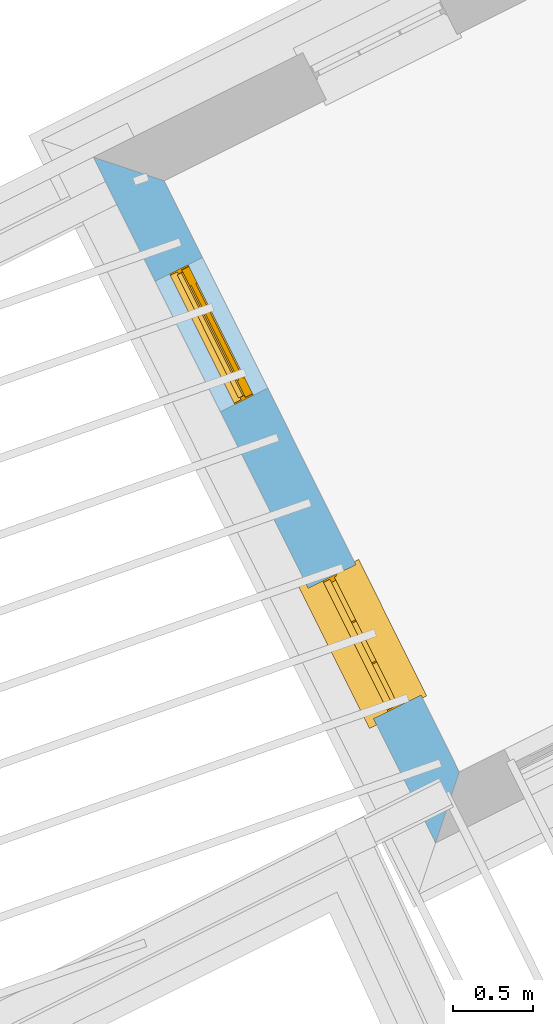
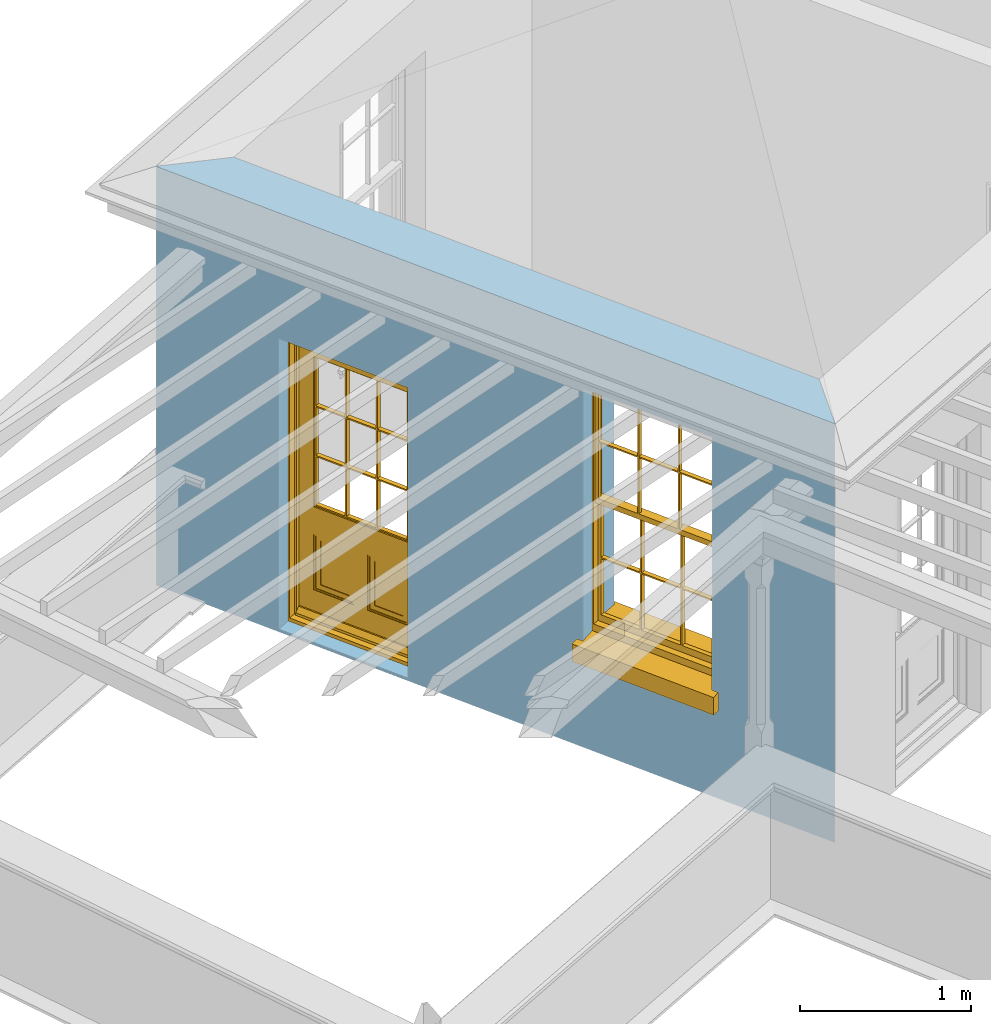
# One storey, part 3 of 7: 1 door, 1 window, 2 openings, plus 1 element that does not belong to this part.
"""IFC2X3 building model written with IfcOpenShell, lengths in metres."""

from ifc_helpers import new_model, si_unit, frame, origin, place, context, subcontext, project, spatial, polyline, outline, extrude, faceted_brep, material, layer, layer_set, layer_usage, element, fill, save


model = new_model("IFC2X3")

# Units and contexts
model_context = context("Model", 3, world=origin())
body_context = subcontext(model_context, "Body", "Model", "MODEL_VIEW")
ifc_project = project(units=[si_unit("PLANEANGLEUNIT", "RADIAN"), si_unit("MASSUNIT", "GRAM", prefix="KILO"), si_unit("FORCEUNIT", "NEWTON", prefix="KILO"), si_unit("LENGTHUNIT", "METRE")], contexts=[model_context])

# Site, building, storey
site_placement = place(None, origin())
site = spatial("IfcSite", under=ifc_project, at=site_placement, CompositionType="ELEMENT")
building_placement = place(None, origin())
building = spatial("IfcBuilding", under=site, at=building_placement, Name="Building plot-8", CompositionType="ELEMENT")
storey_placement = place(None, frame((0.0, 0.0, 6.3)))
storey = spatial("IfcBuildingStorey", under=building, at=storey_placement, Name="Floor 2", CompositionType="ELEMENT", Elevation=6.3)

# Wall, openings, door, window
ifc_material = material(Name="Masonry")
ifc_layer = layer(ifc_material, 0.33, ventilated=False)
ifc_layer_set = layer_set([ifc_layer], Name="My Wall")
ifc_layer_usage = layer_usage(ifc_layer_set, "AXIS2", "NEGATIVE", 0.08)
wall_placement = place(storey_placement, origin())
wall = element("IfcWallStandardCase", 1, at=wall_placement, inside=storey, material=ifc_layer_usage, Name="exterior", context=body_context, shape_type="SweptSolid", body=[
    extrude(outline(polyline([(22.6049906081901, 17.1432536383612), (22.162338538902, 17.2911020254168), (24.2955349008038, 13.0182468981183), (24.4433832878594, 13.4608989674064), (22.6049906081901, 17.1432536383612)])), origin(), (0.0, 0.0, 1.0), 3.0),
])
opening_1_placement = place(storey_placement, frame((0.0, 0.0, 0.0199999999999996)))
opening_1 = element("IfcOpeningElement", 2, at=opening_1_placement, cuts=wall, Name="Opening", ObjectType="Opening", context=body_context, shape_type="SweptSolid", body=[
    extrude(outline(polyline([(22.5482357882612, 16.518138471764), (22.9547075319454, 15.7039636001386), (23.2499577601173, 15.8513654412549), (22.843486016433, 16.6655403128803), (22.5482357882612, 16.518138471764)])), origin(), (0.0, 0.0, 1.0), 2.08),
])
opening_2_placement = place(storey_placement, frame((0.0, 0.0, 0.75)))
opening_2 = element("IfcOpeningElement", 3, at=opening_2_placement, cuts=wall, Name="Opening", ObjectType="Opening", context=body_context, shape_type="SweptSolid", body=[
    extrude(outline(polyline([(23.5031659077604, 14.6053853233965), (23.9096376514446, 13.791210451771), (24.2048878796165, 13.9386122928873), (23.7984161359322, 14.7527871645127), (23.5031659077604, 14.6053853233965)])), origin(), (0.0, 0.0, 1.0), 1.82),
])
door_placement = place(storey_placement, frame((22.7719102035429, 16.6298065332157, 0.0199999999999996), z_axis=(0.0, 0.0, 1.0), x_axis=(0.406471743684261, -0.814174871625426, 0.0)))
door = element("IfcDoor", 4, at=door_placement, inside=storey, Name="circulation outside door", OverallHeight=2.08, OverallWidth=0.91, context=body_context, shape_type="Brep", held_by="IfcProductRepresentation", body=[
    faceted_brep([(0.545, -0.055, 0.265), (0.745, -0.055, 0.265), (0.745, -0.05, 0.265), (0.545, -0.05, 0.265), (0.745, -0.05, 0.58), (0.545, -0.05, 0.58), (0.545, -0.055, 0.58), (0.515, -0.06, 0.235), (0.775, -0.06, 0.235), (0.745, -0.055, 0.58), (0.515, -0.06, 0.61), (0.515, -0.065, 0.235), (0.775, -0.065, 0.235), (0.775, -0.06, 0.61), (0.515, -0.065, 0.61), (0.785, -0.065, 0.225), (0.505, -0.065, 0.225), (0.775, -0.065, 0.61), (0.505, -0.065, 0.62), (0.785, -0.065, 0.62), (0.505, -0.07, 0.225), (0.785, -0.07, 0.225), (0.505, -0.07, 0.62), (0.785, -0.07, 0.62), (0.883, -0.07, 0.075), (0.898, -0.07, 0.075), (0.405, -0.07, 0.62), (0.405, -0.07, 0.225), (0.027, -0.07, 0.075), (0.785, -0.07, 0.82), (0.125, -0.07, 0.82), (0.405, -0.065, 0.62), (0.405, -0.065, 0.225), (0.898, -0.07, 2.068), (0.027, -0.08, 0.075), (0.883, -0.08, 0.075), (0.125, -0.07, 0.225), (0.012, -0.07, 0.075), (0.785, -0.06, 0.82), (0.125, -0.06, 0.82), (0.125, -0.07, 0.62), (0.125, -0.065, 0.62), (0.395, -0.065, 0.61), (0.395, -0.065, 0.235), (0.125, -0.065, 0.225), (0.785, -0.07, 1.895), (0.027, -0.11, 0.045), (0.883, -0.11, 0.045), (0.558333, -0.06, 0.83), (0.351667, -0.06, 0.83), (0.125, -0.07, 1.895), (0.125, -0.06, 1.895), (0.785, -0.06, 1.895), (0.012, -0.07, 2.068), (0.135, -0.065, 0.61), (0.395, -0.06, 0.61), (0.395, -0.06, 0.235), (0.135, -0.065, 0.235), (0.027, -0.11, 0.027), (0.883, -0.11, 0.027), (0.568333, -0.06, 0.83), (0.558333, -0.03, 0.83), (0.351667, -0.03, 0.83), (0.341667, -0.06, 0.83), (0.135, -0.06, 1.185), (0.135, -0.06, 1.53), (0.775, -0.06, 1.53), (0.775, -0.06, 1.185), (0.135, -0.06, 0.61), (0.365, -0.055, 0.58), (0.365, -0.055, 0.265), (0.135, -0.06, 0.235), (0.568333, -0.06, 1.175), (0.558333, -0.06, 1.175), (0.775, -0.06, 0.83), (0.558333, -0.03, 1.175), (0.785, -0.03, 0.82), (0.125, -0.03, 0.82), (0.351667, -0.03, 1.175), (0.351667, -0.06, 1.175), (0.341667, -0.06, 1.175), (0.135, -0.06, 0.83), (0.135, -0.06, 1.175), (0.135, -0.03, 1.185), (0.135, -0.03, 1.53), (0.135, -0.06, 1.54), (0.351667, -0.06, 1.885), (0.558333, -0.06, 1.885), (0.775, -0.03, 1.53), (0.775, -0.03, 1.185), (0.775, -0.06, 1.175), (0.775, -0.06, 1.54), (0.165, -0.055, 0.58), (0.365, -0.05, 0.58), (0.365, -0.05, 0.265), (0.165, -0.055, 0.265), (0.568333, -0.03, 0.83), (0.568333, -0.03, 1.175), (0.568333, -0.06, 1.185), (0.558333, -0.06, 1.185), (0.775, -0.03, 0.83), (0.785, -0.02, 0.82), (0.125, -0.02, 0.82), (0.341667, -0.03, 0.83), (0.341667, -0.03, 1.175), (0.351667, -0.06, 1.185), (0.341667, -0.06, 1.185), (0.135, -0.03, 0.83), (0.341667, -0.03, 1.185), (0.125, -0.03, 1.895), (0.341667, -0.03, 1.53), (0.341667, -0.06, 1.53), (0.135, -0.06, 1.885), (0.341667, -0.06, 1.54), (0.341667, -0.06, 1.885), (0.558333, -0.03, 1.885), (0.351667, -0.03, 1.885), (0.568333, -0.06, 1.885), (0.785, -0.03, 1.895), (0.568333, -0.03, 1.185), (0.568333, -0.06, 1.53), (0.568333, -0.03, 1.53), (0.568333, -0.06, 1.54), (0.775, -0.06, 1.885), (0.165, -0.05, 0.58), (0.165, -0.05, 0.265), (0.775, -0.03, 1.175), (0.558333, -0.06, 1.53), (0.351667, -0.03, 1.185), (0.558333, -0.03, 1.185), (0.505, -0.02, 0.62), (0.405, -0.02, 0.62), (0.125, -0.02, 1.895), (0.785, -0.02, 1.895), (0.351667, -0.06, 1.53), (0.135, -0.03, 1.175), (0.135, -0.03, 1.54), (0.341667, -0.03, 1.54), (0.135, -0.03, 1.885), (0.351667, -0.06, 1.54), (0.558333, -0.03, 1.54), (0.558333, -0.06, 1.54), (0.351667, -0.03, 1.54), (0.775, -0.03, 1.54), (0.568333, -0.03, 1.54), (0.775, -0.03, 1.885), (0.558333, -0.03, 1.53), (0.405, -0.02, 0.225), (0.505, -0.02, 0.225), (0.125, -0.02, 0.62), (0.785, -0.02, 0.62), (0.012, -0.02, 2.068), (0.898, -0.02, 2.068), (0.351667, -0.03, 1.53), (0.341667, -0.03, 1.885), (0.568333, -0.03, 1.885), (0.405, -0.025, 0.225), (0.405, -0.025, 0.62), (0.505, -0.025, 0.62), (0.505, -0.025, 0.225), (0.898, -0.02, 0.027), (0.012, -0.02, 0.027), (0.125, -0.025, 0.62), (0.785, -0.025, 0.62), (0.395, -0.025, 0.235), (0.395, -0.025, 0.61), (0.125, -0.02, 0.225), (0.125, -0.025, 0.225), (0.515, -0.025, 0.61), (0.515, -0.025, 0.235), (0.785, -0.02, 0.225), (0.785, -0.025, 0.225), (0.135, -0.025, 0.61), (0.775, -0.025, 0.61), (0.135, -0.025, 0.235), (0.395, -0.03, 0.235), (0.395, -0.03, 0.61), (0.515, -0.03, 0.61), (0.515, -0.03, 0.235), (0.775, -0.025, 0.235), (0.135, -0.03, 0.61), (0.775, -0.03, 0.61), (0.135, -0.03, 0.235), (0.365, -0.035, 0.265), (0.365, -0.035, 0.58), (0.545, -0.035, 0.58), (0.545, -0.035, 0.265), (0.775, -0.03, 0.235), (0.165, -0.035, 0.58), (0.745, -0.035, 0.58), (0.165, -0.035, 0.265), (0.365, -0.04, 0.58), (0.365, -0.04, 0.265), (0.545, -0.04, 0.58), (0.545, -0.04, 0.265), (0.745, -0.035, 0.265), (0.165, -0.04, 0.58), (0.745, -0.04, 0.58), (0.165, -0.04, 0.265), (0.745, -0.04, 0.265), (0.885, -0.072, 0.025), (0.025, -0.072, 0.025), (0.025, -0.1, 0.025), (0.885, -0.1, 0.025), (0.9, -0.02, 0.025), (0.01, -0.02, 0.025), (0.9, -0.072, 0.025), (0.91, -0.02, 0.0), (0.0, -0.02, 0.0), (0.01, -0.072, 0.025), (0.9, -0.072, 2.07), (0.9, -0.02, 2.07), (0.885, -0.072, 2.055), (0.91, -0.02, 2.08), (0.01, -0.02, 2.07), (0.0, -0.02, 2.08), (0.01, -0.072, 2.07), (0.025, -0.072, 2.055), (0.0, -0.15, 2.08), (0.91, -0.15, 2.08), (0.01, -0.15, 2.07), (0.9, -0.15, 2.07), (0.01, -0.1, 2.07), (0.9, -0.1, 2.07), (0.0, -0.15, 0.0), (0.91, -0.15, 0.0), (0.01, -0.15, 0.025), (0.9, -0.15, 0.025), (0.01, -0.1, 0.025), (0.025, -0.1, 2.055), (0.9, -0.1, 0.025), (0.885, -0.1, 2.055), (0.898, -0.07, 0.027), (0.012, -0.07, 0.027), (0.883, -0.07, 0.027), (0.027, -0.07, 0.027)], [[[0, 1, 2, 3]], [[2, 4, 5, 3]], [[0, 3, 5, 6]], [[1, 0, 7, 8]], [[9, 4, 2, 1]], [[9, 6, 5, 4]], [[0, 6, 10, 7]], [[8, 7, 11, 12]], [[8, 13, 9, 1]], [[13, 10, 6, 9]], [[7, 10, 14, 11]], [[15, 12, 11, 16]], [[12, 17, 13, 8]], [[17, 14, 10, 13]], [[18, 16, 11, 14]], [[15, 19, 17, 12]], [[15, 16, 20, 21]], [[14, 17, 19, 18]], [[16, 18, 22, 20]], [[21, 23, 19, 15]], [[24, 25, 21, 20]], [[23, 22, 18, 19]], [[20, 22, 26, 27]], [[23, 21, 25]], [[28, 24, 20, 27]], [[22, 23, 29]], [[29, 30, 26, 22]], [[27, 26, 31, 32]], [[23, 25, 33, 29]], [[34, 35, 24, 28]], [[28, 27, 36, 37]], [[38, 39, 30, 29]], [[26, 30, 40]], [[26, 40, 41, 31]], [[42, 43, 32, 31]], [[32, 44, 36, 27]], [[33, 45, 29]], [[46, 47, 35, 34]], [[36, 40, 37]], [[39, 38, 48, 49]], [[50, 30, 39, 51]], [[29, 45, 52, 38]], [[53, 37, 40, 30]], [[44, 41, 40, 36]], [[31, 41, 54, 42]], [[43, 42, 55, 56]], [[57, 44, 32, 43]], [[50, 45, 33, 53]], [[47, 46, 58, 59]], [[60, 48, 38]], [[49, 48, 61, 62]], [[49, 63, 39]], [[50, 53, 30]], [[51, 39, 64, 65]], [[45, 50, 51, 52]], [[66, 67, 38, 52]], [[57, 54, 41, 44]], [[42, 54, 68, 55]], [[56, 55, 69, 70]], [[56, 71, 57, 43]], [[60, 72, 73, 48]], [[60, 38, 74]], [[48, 73, 75, 61]], [[76, 77, 62, 61]], [[62, 78, 79, 49]], [[49, 79, 80, 63]], [[63, 81, 39]], [[82, 64, 39]], [[65, 64, 83, 84]], [[85, 51, 65]], [[52, 51, 86, 87]], [[88, 89, 67, 66]], [[90, 38, 67]], [[91, 66, 52]], [[71, 68, 54, 57]], [[55, 68, 92, 69]], [[69, 93, 94, 70]], [[70, 95, 71, 56]], [[96, 97, 72, 60]], [[73, 72, 98, 99]], [[74, 38, 90]], [[100, 96, 60, 74]], [[75, 73, 79, 78]], [[61, 75, 97, 96]], [[101, 102, 77, 76]], [[77, 103, 62]], [[96, 76, 61]], [[103, 104, 78, 62]], [[80, 79, 105, 106]], [[63, 80, 104, 103]], [[81, 63, 103, 107]], [[81, 82, 39]], [[106, 64, 82, 80]], [[106, 108, 83, 64]], [[84, 83, 77, 109]], [[110, 111, 65, 84]], [[112, 51, 85]], [[113, 85, 65, 111]], [[114, 86, 51]], [[115, 87, 86, 116]], [[117, 52, 87]], [[118, 76, 89, 88]], [[119, 98, 67, 89]], [[120, 121, 88, 66]], [[67, 98, 72, 90]], [[91, 122, 120, 66]], [[91, 52, 123]], [[95, 92, 68, 71]], [[69, 92, 124, 93]], [[94, 93, 124, 125]], [[94, 125, 95, 70]], [[72, 97, 126, 90]], [[127, 99, 98, 120]], [[99, 105, 79, 73]], [[74, 90, 126, 100]], [[96, 100, 76]], [[128, 129, 75, 78]], [[97, 75, 129, 119]], [[130, 131, 102, 101]], [[109, 77, 102, 132]], [[133, 101, 76, 118]], [[77, 107, 103]], [[78, 104, 108, 128]], [[111, 106, 105, 134]], [[104, 80, 82, 135]], [[107, 135, 82, 81]], [[110, 108, 106, 111]], [[104, 135, 83, 108]], [[83, 135, 77]], [[136, 84, 109]], [[110, 84, 136, 137]], [[114, 51, 112]], [[85, 136, 138, 112]], [[113, 137, 136, 85]], [[111, 134, 139, 113]], [[86, 114, 113, 139]], [[140, 141, 87, 115]], [[139, 142, 116, 86]], [[109, 118, 115, 116]], [[117, 123, 52]], [[117, 87, 141, 122]], [[126, 89, 76]], [[143, 118, 88]], [[120, 98, 119, 121]], [[119, 89, 126, 97]], [[144, 143, 88, 121]], [[144, 122, 91, 143]], [[127, 120, 122, 141]], [[143, 91, 123, 145]], [[124, 92, 95, 125]], [[146, 129, 99, 127]], [[99, 129, 128, 105]], [[100, 126, 76]], [[121, 119, 129, 146]], [[147, 131, 130, 148]], [[131, 149, 102]], [[130, 101, 150]], [[102, 151, 132]], [[118, 109, 132, 133]], [[101, 133, 152]], [[107, 77, 135]], [[153, 128, 108, 110]], [[134, 105, 128, 153]], [[109, 138, 136]], [[153, 110, 137, 142]], [[154, 114, 112, 138]], [[137, 113, 114, 154]], [[141, 139, 134, 127]], [[141, 140, 142, 139]], [[144, 140, 115, 155]], [[142, 137, 154, 116]], [[155, 115, 118]], [[116, 154, 109]], [[117, 155, 145, 123]], [[122, 144, 155, 117]], [[143, 145, 118]], [[121, 146, 140, 144]], [[146, 127, 134, 153]], [[156, 157, 131, 147]], [[148, 130, 158, 159]], [[148, 160, 161, 147]], [[157, 162, 149, 131]], [[161, 151, 102, 149]], [[101, 152, 160, 150]], [[163, 158, 130, 150]], [[151, 152, 133, 132]], [[154, 138, 109]], [[142, 140, 146, 153]], [[145, 155, 118]], [[157, 156, 164, 165]], [[147, 166, 167, 156]], [[168, 169, 159, 158]], [[170, 148, 159, 171]], [[148, 170, 160]], [[166, 147, 161]], [[172, 162, 157, 165]], [[166, 149, 162, 167]], [[166, 161, 149]], [[150, 160, 170]], [[163, 173, 168, 158]], [[171, 163, 150, 170]], [[174, 164, 156, 167]], [[175, 176, 165, 164]], [[169, 168, 177, 178]], [[171, 159, 169, 179]], [[167, 162, 172, 174]], [[176, 180, 172, 165]], [[179, 173, 163, 171]], [[181, 177, 168, 173]], [[164, 174, 182, 175]], [[183, 184, 176, 175]], [[178, 177, 185, 186]], [[179, 169, 178, 187]], [[174, 172, 180, 182]], [[184, 188, 180, 176]], [[187, 181, 173, 179]], [[189, 185, 177, 181]], [[175, 182, 190, 183]], [[191, 184, 183, 192]], [[185, 193, 194, 186]], [[187, 178, 186, 195]], [[182, 180, 188, 190]], [[191, 196, 188, 184]], [[195, 189, 181, 187]], [[197, 193, 185, 189]], [[183, 190, 198, 192]], [[198, 196, 191, 192]], [[194, 193, 197, 199]], [[195, 186, 194, 199]], [[188, 196, 198, 190]], [[197, 189, 195, 199]], [[200, 201, 202, 203]], [[201, 200, 204, 205]], [[206, 204, 200]], [[204, 207, 208, 205]], [[209, 201, 205]], [[210, 211, 204, 206]], [[206, 200, 212, 210]], [[211, 213, 207, 204]], [[214, 205, 208, 215]], [[216, 217, 201, 209]], [[205, 214, 216, 209]], [[216, 214, 211, 210]], [[210, 212, 217, 216]], [[214, 215, 213, 211]], [[218, 219, 213, 215]], [[219, 218, 220, 221]], [[221, 220, 222, 223]], [[215, 208, 224, 218]], [[225, 224, 208, 207]], [[224, 226, 220, 218]], [[224, 225, 227, 226]], [[219, 225, 207, 213]], [[228, 222, 220, 226]], [[219, 221, 227, 225]], [[226, 227, 203, 202]], [[202, 229, 222, 228]], [[228, 226, 202]], [[227, 221, 223, 230]], [[230, 203, 227]], [[217, 229, 202, 201]], [[231, 223, 222, 229]], [[230, 223, 231, 203]], [[231, 229, 217, 212]], [[212, 200, 203, 231]], [[33, 152, 151, 53]], [[25, 160, 152, 33]], [[161, 37, 53, 151]], [[232, 160, 25]], [[161, 233, 37]], [[160, 232, 234]], [[24, 234, 232, 25]], [[233, 161, 235]], [[37, 233, 235, 28]], [[161, 160, 234, 235]], [[35, 47, 234, 24]], [[28, 235, 46, 34]], [[58, 235, 234, 59]], [[59, 234, 47]], [[58, 46, 235]]]),
])
fill(opening_1, door)
window_placement = place(storey_placement, frame((23.7268403230421, 14.7170533848482, 0.75), z_axis=(0.0, 0.0, 1.0), x_axis=(0.406471743684261, -0.814174871625426, 0.0)))
window = element("IfcWindow", 5, at=window_placement, inside=storey, Name="circulation outside window", OverallHeight=1.82, OverallWidth=0.91, context=body_context, shape_type="Brep", held_by="IfcProductRepresentation", body=[
    faceted_brep([(0.033125, -0.105, 0.975209), (0.01, -0.105, 0.975209), (0.033125, -0.105, 1.376042), (0.876875, -0.105, 0.975209), (0.876875, -0.105, 1.376042), (0.9, -0.105, 0.975209), (0.876875, -0.105, 1.386042), (0.876875, -0.105, 1.786875), (0.9, -0.105, 1.81), (0.033125, -0.105, 1.786875), (0.033125, -0.105, 1.386042), (0.01, -0.105, 1.81), (0.876875, -0.135, 1.376042), (0.876875, -0.135, 0.975209), (0.9, -0.135, 0.937083), (0.033125, -0.135, 1.786875), (0.01, -0.135, 1.81), (0.033125, -0.135, 1.386042), (0.01, -0.135, 0.937083), (0.033125, -0.135, 0.975209), (0.033125, -0.135, 1.376042), (0.876875, -0.135, 1.786875), (0.876875, -0.135, 1.386042), (0.9, -0.135, 1.81), (0.033125, -0.105, 0.937083), (0.01, -0.105, 0.937083), (0.033125, -0.105, 0.53625), (0.876875, -0.105, 0.937083), (0.876875, -0.105, 0.53625), (0.9, -0.105, 0.937083), (0.876875, -0.105, 0.52625), (0.876875, -0.105, 0.125417), (0.9, -0.105, 0.077167), (0.033125, -0.105, 0.125417), (0.033125, -0.105, 0.52625), (0.01, -0.105, 0.077167), (-0.0425, -0.25, 0.01), (-0.0425, -0.3, 0.001667), (0.0, -0.25, 0.01), (0.9525, -0.25, 0.01), (0.91, -0.25, 0.01), (0.9525, -0.3, 0.001667), (-0.02, 0.08, 0.077167), (0.0, 0.08, 0.077167), (-0.02, 0.11, 0.077167), (0.0, -0.06, 0.077167), (0.01, -0.06, 0.077167), (0.91, -0.06, 0.077167), (0.91, 0.08, 0.077167), (0.9, -0.06, 0.077167), (0.93, 0.08, 0.077167), (0.93, 0.11, 0.077167), (0.01, -0.075, 0.975209), (0.9, -0.075, 0.975209), (0.876875, -0.075, 0.125417), (0.876875, -0.075, 0.52625), (0.9, -0.075, 0.077167), (0.876875, -0.075, 0.53625), (0.876875, -0.075, 0.937083), (0.033125, -0.075, 0.125417), (0.01, -0.075, 0.077167), (0.033125, -0.075, 0.52625), (0.033125, -0.075, 0.937083), (0.033125, -0.075, 0.53625), (-0.02, 0.08, 0.052167), (-0.02, 0.11, 0.052167), (0.93, 0.11, 0.052167), (0.93, 0.08, 0.052167), (0.91, 0.08, 0.052167), (0.0, 0.08, 0.052167), (0.91, -0.15, 0.026667), (0.0, -0.15, 0.026667), (-0.0425, -0.3, -0.123333), (0.9525, -0.3, -0.123333), (-0.0425, -0.25, -0.123333), (0.9525, -0.25, -0.123333), (0.01, -0.06, 1.81), (0.9, -0.06, 1.81), (0.0, -0.06, 1.82), (0.91, -0.06, 1.82), (0.01, -0.15, 0.077167), (0.9, -0.15, 0.077167), (0.592292, -0.105, 0.125417), (0.592292, -0.075, 0.125417), (0.317708, -0.075, 0.125417), (0.317708, -0.105, 0.125417), (0.592292, -0.105, 0.53625), (0.317708, -0.105, 0.53625), (0.317708, -0.105, 0.52625), (0.592292, -0.105, 0.52625), (0.592292, -0.075, 0.53625), (0.317708, -0.075, 0.53625), (0.592292, -0.135, 1.386042), (0.592292, -0.105, 1.386042), (0.317708, -0.105, 1.386042), (0.317708, -0.135, 1.386042), (0.317708, -0.135, 1.376042), (0.592292, -0.135, 1.376042), (0.317708, -0.105, 1.376042), (0.592292, -0.105, 1.376042), (0.602292, -0.135, 1.376042), (0.592292, -0.135, 0.975209), (0.602292, -0.135, 0.975209), (0.602292, -0.105, 0.975209), (0.592292, -0.105, 0.975209), (0.602292, -0.105, 1.376042), (0.602292, -0.075, 0.53625), (0.602292, -0.105, 0.53625), (0.317708, -0.075, 0.52625), (0.307708, -0.075, 0.125417), (0.307708, -0.075, 0.52625), (0.602292, -0.075, 0.52625), (0.602292, -0.075, 0.125417), (0.592292, -0.075, 0.52625), (0.307708, -0.075, 0.53625), (0.317708, -0.075, 0.937083), (0.307708, -0.075, 0.937083), (0.602292, -0.075, 0.937083), (0.592292, -0.075, 0.937083), (0.307708, -0.105, 0.52625), (0.307708, -0.105, 0.125417), (0.307708, -0.105, 0.53625), (0.307708, -0.105, 0.937083), (0.592292, -0.105, 0.937083), (0.317708, -0.105, 0.937083), (0.602292, -0.105, 0.937083), (0.602292, -0.105, 0.52625), (0.602292, -0.105, 0.125417), (0.307708, -0.135, 1.386042), (0.307708, -0.135, 1.376042), (0.307708, -0.135, 0.975209), (0.317708, -0.135, 0.975209), (0.317708, -0.135, 1.786875), (0.307708, -0.135, 1.786875), (0.602292, -0.135, 1.786875), (0.592292, -0.135, 1.786875), (0.602292, -0.135, 1.386042), (0.602292, -0.105, 1.386042), (0.307708, -0.105, 1.386042), (0.307708, -0.105, 1.786875), (0.317708, -0.105, 1.786875), (0.592292, -0.105, 1.786875), (0.602292, -0.105, 1.786875), (0.307708, -0.105, 1.376042), (0.317708, -0.105, 0.975209), (0.307708, -0.105, 0.975209), (0.91, -0.15, 1.82), (0.9, -0.15, 1.81), (0.01, -0.15, 1.81), (0.0, -0.15, 1.82), (0.91, -0.25, 0.0), (0.0, -0.25, 0.0), (0.91, 0.08, 0.0), (0.0, 0.08, 0.0)], [[[0, 1, 2]], [[3, 4, 5]], [[6, 7, 8]], [[9, 10, 11]], [[12, 13, 14]], [[15, 16, 17]], [[18, 19, 20]], [[21, 22, 23]], [[24, 25, 26]], [[27, 28, 29]], [[30, 31, 32]], [[33, 34, 35]], [[14, 27, 29]], [[25, 24, 18]], [[36, 37, 38]], [[39, 40, 41]], [[42, 43, 44]], [[45, 46, 43]], [[47, 48, 49]], [[50, 51, 48]], [[1, 0, 52]], [[5, 53, 3]], [[54, 55, 56]], [[57, 58, 53]], [[59, 60, 61]], [[62, 63, 52]], [[48, 43, 46, 49]], [[51, 44, 43, 48]], [[64, 42, 44, 65]], [[65, 44, 51, 66]], [[66, 51, 50, 67]], [[65, 66, 68, 69]], [[60, 56, 49, 46]], [[70, 71, 38, 40]], [[37, 41, 40, 38]], [[37, 72, 73, 41]], [[74, 75, 73, 72]], [[8, 11, 76, 77]], [[76, 78, 79, 77]], [[32, 35, 80, 81]], [[81, 80, 71, 70]], [[82, 83, 84, 85]], [[86, 87, 88, 89]], [[86, 90, 91, 87]], [[92, 93, 94, 95]], [[92, 95, 96, 97]], [[96, 98, 99, 97]], [[100, 97, 101, 102]], [[103, 104, 99, 105]], [[97, 99, 104, 101]], [[102, 103, 105, 100]], [[28, 57, 106, 107]], [[108, 84, 109, 110]], [[111, 112, 83, 113]], [[114, 110, 61, 63]], [[90, 113, 108, 91]], [[115, 91, 114, 116]], [[117, 106, 90, 118]], [[111, 106, 57, 55]], [[119, 110, 109, 120]], [[34, 61, 110, 119]], [[89, 113, 83, 82]], [[88, 108, 113, 89]], [[85, 84, 108, 88]], [[121, 114, 63, 26]], [[122, 116, 114, 121]], [[123, 118, 90, 86]], [[87, 91, 115, 124]], [[107, 106, 117, 125]], [[126, 111, 55, 30]], [[127, 112, 111, 126]], [[126, 30, 28, 107]], [[88, 119, 120, 85]], [[126, 89, 82, 127]], [[125, 123, 86, 107]], [[121, 26, 34, 119]], [[124, 122, 121, 87]], [[128, 17, 20, 129]], [[96, 129, 130, 131]], [[132, 133, 128, 95]], [[134, 135, 92, 136]], [[100, 12, 22, 136]], [[137, 6, 4, 105]], [[94, 138, 139, 140]], [[137, 93, 141, 142]], [[99, 98, 94, 93]], [[143, 2, 10, 138]], [[144, 145, 143, 98]], [[129, 143, 145, 130]], [[20, 2, 143, 129]], [[131, 144, 98, 96]], [[128, 138, 10, 17]], [[133, 139, 138, 128]], [[135, 141, 93, 92]], [[95, 94, 140, 132]], [[22, 6, 137, 136]], [[136, 137, 142, 134]], [[100, 105, 4, 12]], [[107, 86, 89, 126]], [[106, 111, 113, 90]], [[91, 108, 110, 114]], [[87, 121, 119, 88]], [[97, 100, 136, 92]], [[129, 96, 95, 128]], [[98, 143, 138, 94]], [[105, 99, 93, 137]], [[131, 101, 104, 144]], [[124, 115, 118, 123]], [[132, 140, 141, 135]], [[120, 109, 59, 33]], [[15, 9, 139, 133]], [[134, 142, 7, 21]], [[31, 54, 112, 127]], [[36, 74, 72, 37]], [[39, 41, 73, 75]], [[18, 14, 101, 131]], [[23, 16, 132, 135]], [[83, 56, 60, 84]], [[52, 53, 118, 115]], [[53, 52, 144, 104]], [[11, 8, 141, 140]], [[14, 18, 124, 123]], [[2, 1, 11, 10]], [[8, 5, 4, 6]], [[57, 53, 56, 55]], [[60, 52, 63, 61]], [[26, 25, 35, 34]], [[32, 29, 28, 30]], [[14, 23, 22, 12]], [[18, 20, 17, 16]], [[19, 0, 2, 20]], [[17, 10, 9, 15]], [[12, 4, 3, 13]], [[21, 7, 6, 22]], [[27, 58, 57, 28]], [[30, 55, 54, 31]], [[33, 59, 61, 34]], [[26, 63, 62, 24]], [[5, 8, 77, 53]], [[76, 11, 1, 52]], [[46, 45, 78, 76]], [[49, 77, 79, 47]], [[70, 146, 147, 81]], [[71, 80, 148, 149]], [[19, 130, 145, 0]], [[102, 13, 3, 103]], [[116, 122, 24, 62]], [[29, 32, 81, 14]], [[80, 35, 25, 18]], [[60, 46, 76, 52]], [[77, 49, 56, 53]], [[23, 14, 81, 147]], [[16, 148, 80, 18]], [[35, 85, 120]], [[120, 33, 35]], [[127, 82, 32]], [[32, 31, 127]], [[32, 82, 85, 35]], [[102, 101, 14]], [[14, 13, 102]], [[18, 131, 130]], [[130, 19, 18]], [[134, 21, 23]], [[23, 135, 134]], [[16, 15, 133]], [[133, 132, 16]], [[11, 140, 139]], [[139, 9, 11]], [[142, 141, 8]], [[8, 7, 142]], [[23, 147, 148, 16]], [[146, 149, 148, 147]], [[52, 115, 116]], [[116, 62, 52]], [[118, 53, 117]], [[58, 117, 53]], [[27, 125, 117, 58]], [[56, 83, 112]], [[112, 54, 56]], [[109, 84, 60]], [[60, 59, 109]], [[125, 27, 14]], [[14, 123, 125]], [[122, 124, 18]], [[18, 24, 122]], [[145, 144, 52]], [[52, 0, 145]], [[103, 3, 53]], [[53, 104, 103]], [[79, 78, 149, 146]], [[78, 45, 71, 149]], [[146, 70, 47, 79]], [[150, 75, 74, 151]], [[68, 66, 67]], [[48, 68, 67, 50]], [[69, 64, 65]], [[42, 64, 69, 43]], [[69, 68, 152, 153]], [[70, 68, 48, 47]], [[150, 152, 68, 70]], [[43, 69, 71, 45]], [[69, 153, 151, 71]], [[152, 150, 151, 153]], [[38, 151, 74, 36]], [[71, 151, 38]], [[39, 75, 150, 40]], [[40, 150, 70]]]),
])
fill(opening_2, window)

save(model, "model.ifc")
